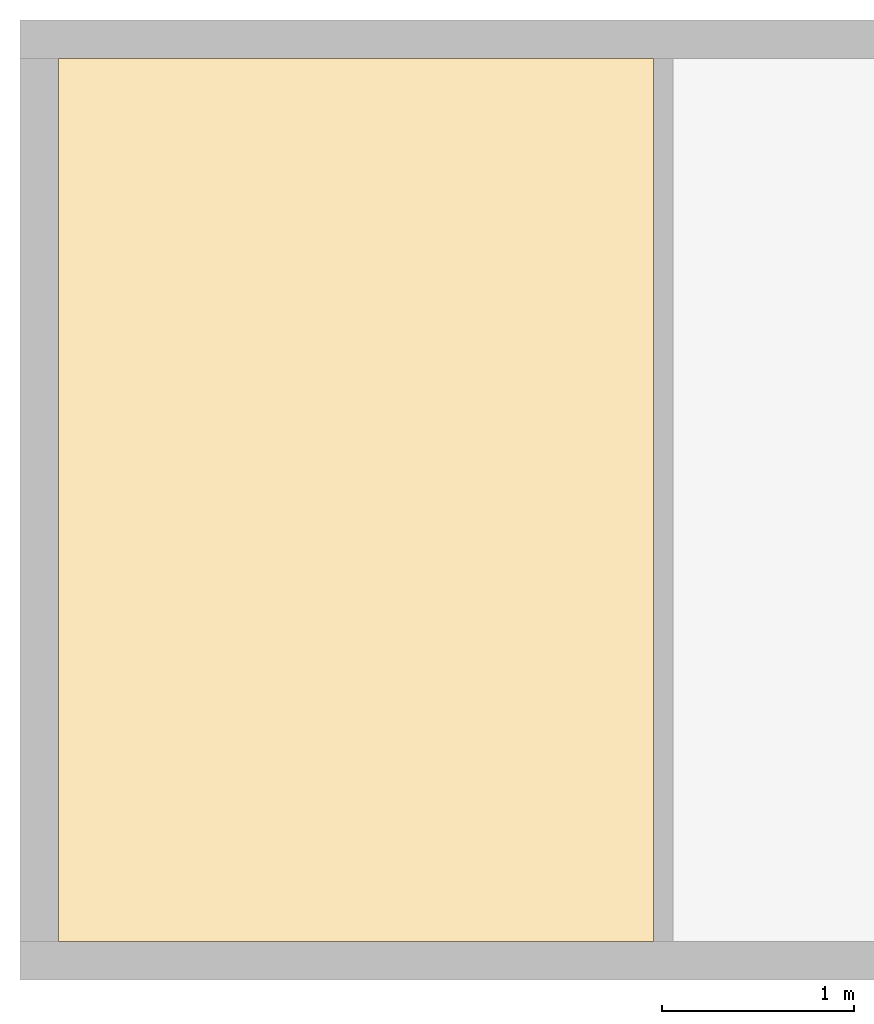
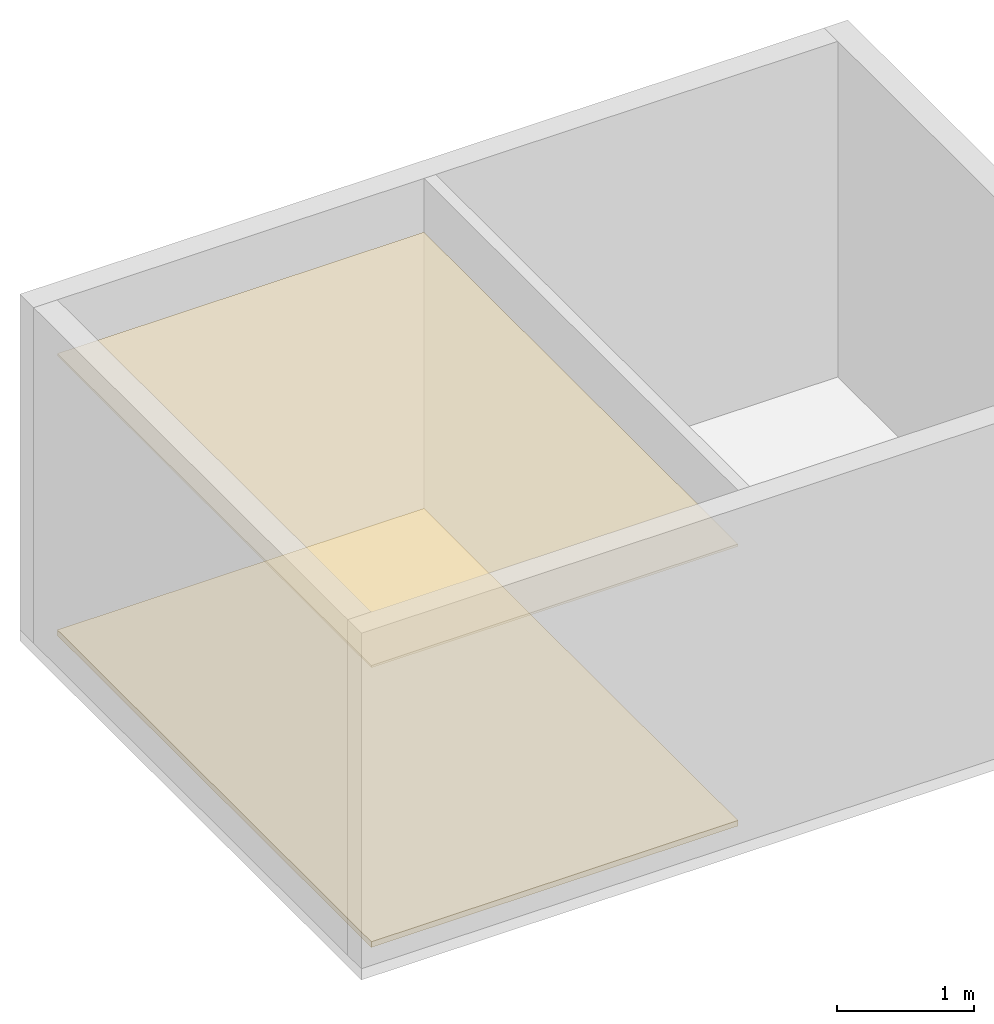
# One storey, part 2 of 2: 2 coverings.
"""IFC4 building model written with IfcOpenShell, lengths in metres."""

from ifc_helpers import new_model, entity, si_unit, converted_unit, frame, origin_with_axes, origin_2d_with_axis, place, context, subcontext, project, spatial, line, indexed_curve, outline, extrude, material, layer, layer_set, layer_usage, type_object, element, save


model = new_model("IFC4")

# Units and contexts
model_context = context("Model", 3, precision=1e-05, world=origin_with_axes())
plan_context = context("Plan", 2, precision=1e-05, world=origin_2d_with_axis())
body_context = subcontext(model_context, "Body", "Model", "MODEL_VIEW")
ifc_project = project(units=[si_unit("VOLUMEUNIT", "CUBIC_METRE"), si_unit("LENGTHUNIT", "METRE"), converted_unit("PLANEANGLEUNIT", "degree", entity("IfcReal", 0.0174532925199433), si_unit("PLANEANGLEUNIT", "RADIAN"), dimensions=[0, 0, 0, 0, 0, 0, 0]), si_unit("AREAUNIT", "SQUARE_METRE")], contexts=[model_context, plan_context])

# Site, building, storey, space
site_placement = place(None, origin_with_axes())
site = spatial("IfcSite", under=ifc_project, at=site_placement)
building_placement = place(site_placement, origin_with_axes())
building = spatial("IfcBuilding", under=site, at=building_placement, Name="Building")
storey_placement = place(building_placement, origin_with_axes())
storey = spatial("IfcBuildingStorey", under=building, at=storey_placement, Name="Storey")
space_placement = place(storey_placement, frame((1.90752410888672, 0.740174770355225, 0.0), z_axis=(0.0, 0.0, 1.0), x_axis=(1.0, 0.0, 0.0)))
space = spatial("IfcSpace", under=storey, at=space_placement)

# Coverings
ifc_material = material()
ifc_layer_1 = layer(ifc_material, 0.0500000007450581)
ifc_layer_set_1 = layer_set([ifc_layer_1])
ifc_layer_usage_1 = layer_usage(ifc_layer_set_1, "AXIS3", "POSITIVE", 0.0)
covering_type_1 = type_object("IfcCoveringType", Name="FLR-01", PredefinedType="FLOORING", material=ifc_layer_set_1)
covering_1_placement = place(space_placement, frame((-1.707524061203, -0.540174782276154, 0.0), z_axis=(0.0, 0.0, 1.0), x_axis=(1.0, 0.0, 0.0)))
element("IfcCovering", 1, at=covering_1_placement, inside=space, type_object=covering_type_1, material=ifc_layer_usage_1, Name="floor.001", PredefinedType="FLOORING", context=body_context, shape_type="SweptSolid", body=[
    extrude(outline(indexed_curve([(0.0, 0.0), (3.10065317153931, 0.0), (3.10065317153931, 4.60000038146973), (0.0, 4.60000038146973)], segments=[line(3, 2), line(2, 1), line(1, 4), line(4, 3)], self_intersect=False)), None, (0.0, 0.0, 1.0), 0.0500000007450581),
])
ifc_layer_2 = layer(ifc_material, 0.0199999995529652)
ifc_layer_set_2 = layer_set([ifc_layer_2])
ifc_layer_usage_2 = layer_usage(ifc_layer_set_2, "AXIS3", "POSITIVE", 0.0)
covering_type_2 = type_object("IfcCoveringType", Name="CEL-01", PredefinedType="CEILING", material=ifc_layer_set_2)
covering_2_placement = place(space_placement, frame((-1.707524061203, -0.540174782276154, 2.5), z_axis=(0.0, 0.0, 1.0), x_axis=(1.0, 0.0, 0.0)))
element("IfcCovering", 2, at=covering_2_placement, inside=space, type_object=covering_type_2, material=ifc_layer_usage_2, Name="ceiling", context=body_context, shape_type="SweptSolid", body=[
    extrude(outline(indexed_curve([(0.0, 0.0), (3.10065078735352, 0.0), (3.10065078735352, 4.60000133514404), (0.0, 4.60000133514404)], segments=[line(3, 2), line(2, 1), line(1, 4), line(4, 3)], self_intersect=False)), None, (0.0, 0.0, 1.0), 0.0199999995529652),
])

save(model, "model.ifc")
